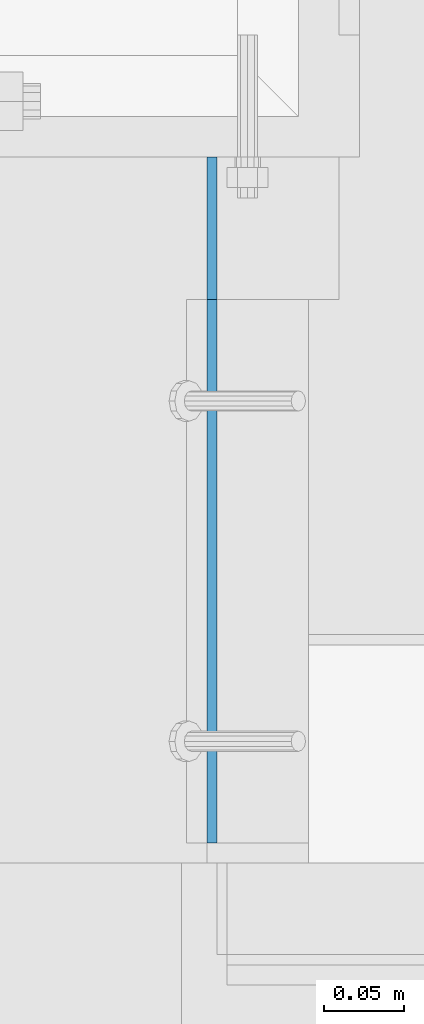
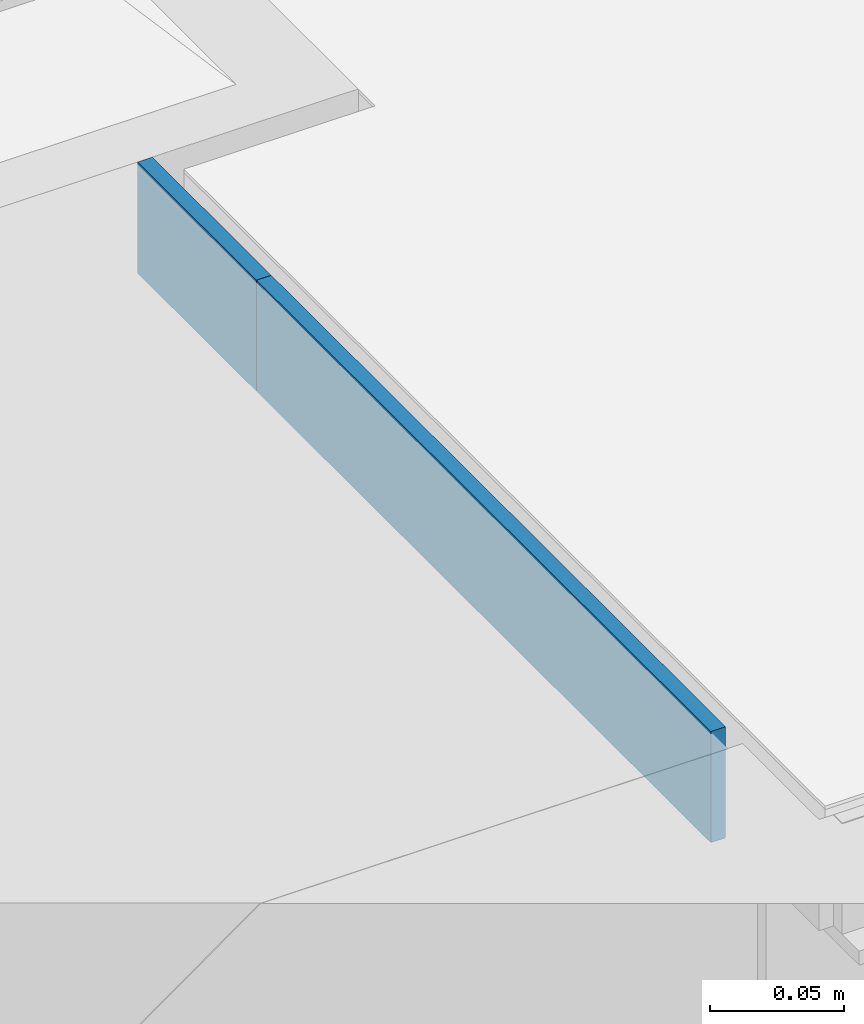
# One storey, part 3056 of 3843: 2 plates, 2 elements without a shape of their own.
"""IFC2X3 building model written with IfcOpenShell, lengths in millimetres."""

from ifc_helpers import new_model, si_unit, frame, origin_with_axes, place, context, subcontext, project, spatial, faceted_brep, material, type_object, element, aggregate, save


model = new_model("IFC2X3")

# Units and contexts
model_context = context("Model", 3, precision=1e-05, world=origin_with_axes())
body_context = subcontext(model_context, "Body", "Model", "MODEL_VIEW")
ifc_project = project(units=[si_unit("LENGTHUNIT", "METRE", prefix="MILLI"), si_unit("AREAUNIT", "SQUARE_METRE"), si_unit("VOLUMEUNIT", "CUBIC_METRE"), si_unit("MASSUNIT", "GRAM", prefix="KILO"), si_unit("TIMEUNIT", "SECOND"), si_unit("PLANEANGLEUNIT", "RADIAN"), si_unit("SOLIDANGLEUNIT", "STERADIAN"), si_unit("THERMODYNAMICTEMPERATUREUNIT", "DEGREE_CELSIUS"), si_unit("LUMINOUSINTENSITYUNIT", "LUMEN")], contexts=[model_context])

# Site, building, storey
site_placement = place(None, origin_with_axes())
site = spatial("IfcSite", under=ifc_project, at=site_placement, CompositionType="ELEMENT")
building_placement = place(site_placement, origin_with_axes())
building = spatial("IfcBuilding", under=site, at=building_placement, Name="Undefined", CompositionType="ELEMENT")
storey_placement = place(building_placement, origin_with_axes())
storey = spatial("IfcBuildingStorey", under=building, at=storey_placement, Name="Undefined", CompositionType="ELEMENT", Elevation=0.0)

# Assembly, plate
assembly_1_placement = place(storey_placement, origin_with_axes())
assembly_1 = element("IfcElementAssembly", 1, at=assembly_1_placement, inside=storey, Name="GRATING", AssemblyPlace="NOTDEFINED", PredefinedType="NOTDEFINED")
ifc_material = material(Name="STEEL/A36")
plate_type = type_object("IfcPlateType", PredefinedType="NOTDEFINED")
plate_1_placement = place(assembly_1_placement, frame((56080.025000002, 14681.1997676562, 30429.2000030518), z_axis=(0.0, 0.999999999997942, -2.02899998962774e-06), x_axis=(0.0, 2.02899999567308e-06, 0.999999999997942)))
plate_1 = element("IfcPlate", 2, at=plate_1_placement, type_object=plate_type, material=ifc_material, Name="PLATE", context=body_context, shape_type="Brep", body=[
    faceted_brep([(0.0, -3.17499999999927, 0.0), (0.000179417467734311, -3.17500000026484, 88.9001281746187), (0.000179417467734311, 3.17499999974098, 88.900128174615), (0.0, 3.17499999999927, 0.0), (50.8001812234725, -3.17500000026484, 88.9000671394897), (50.8001812234725, 3.17499999974098, 88.9000671394861), (50.7999954217848, -3.17499999999563, -7.27595761418343e-12), (50.7999954217848, 3.17500000001019, -1.09139364212751e-11)], [[[0, 1, 2, 3]], [[1, 4, 5, 2]], [[4, 6, 7, 5]], [[6, 0, 3, 7]], [[5, 7, 3, 2]], [[6, 4, 1, 0]]]),
])
aggregate(assembly_1, [plate_1])

assembly_2_placement = place(storey_placement, origin_with_axes())
assembly_2 = element("IfcElementAssembly", 3, at=assembly_2_placement, inside=storey, Name="ANGLE", AssemblyPlace="NOTDEFINED", PredefinedType="RIGID_FRAME")
plate_2_placement = place(assembly_2_placement, frame((56080.025000002, 14341.4747676204, 30429.2000030518), z_axis=(0.0, 0.999999999997942, -2.02899998962774e-06), x_axis=(0.0, 2.02899999567308e-06, 0.999999999997942)))
plate_2 = element("IfcPlate", 4, at=plate_2_placement, type_object=plate_type, material=ifc_material, Name="PLATE", context=body_context, shape_type="Brep", body=[
    faceted_brep([(0.0, -3.17499999999927, 0.0), (0.000684076421748614, -3.17499999939901, 339.725128173899), (0.000684076421748614, 3.17500000059954, 339.725128173899), (0.0, 3.17499999999927, 0.0), (50.8006858829212, -3.17499999939901, 339.72506713877), (50.8006858829212, 3.17500000059954, 339.72506713877), (50.7999954217848, -3.17499999999563, -7.27595761418343e-12), (50.7999954217848, 3.17500000001019, -1.09139364212751e-11)], [[[0, 1, 2, 3]], [[1, 4, 5, 2]], [[4, 6, 7, 5]], [[6, 0, 3, 7]], [[5, 7, 3, 2]], [[6, 4, 1, 0]]]),
])
aggregate(assembly_2, [plate_2])

save(model, "model.ifc")
